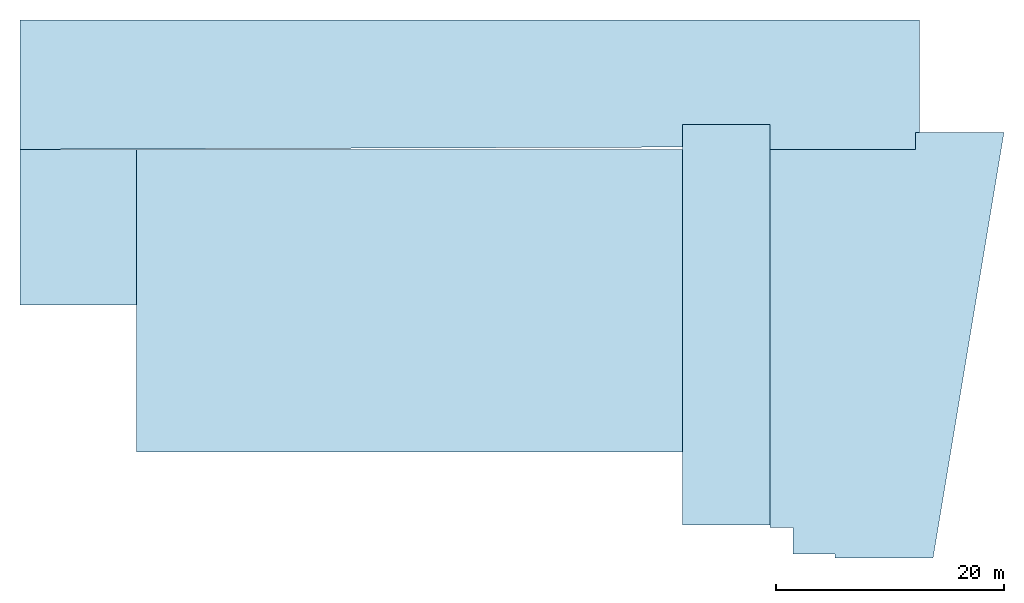
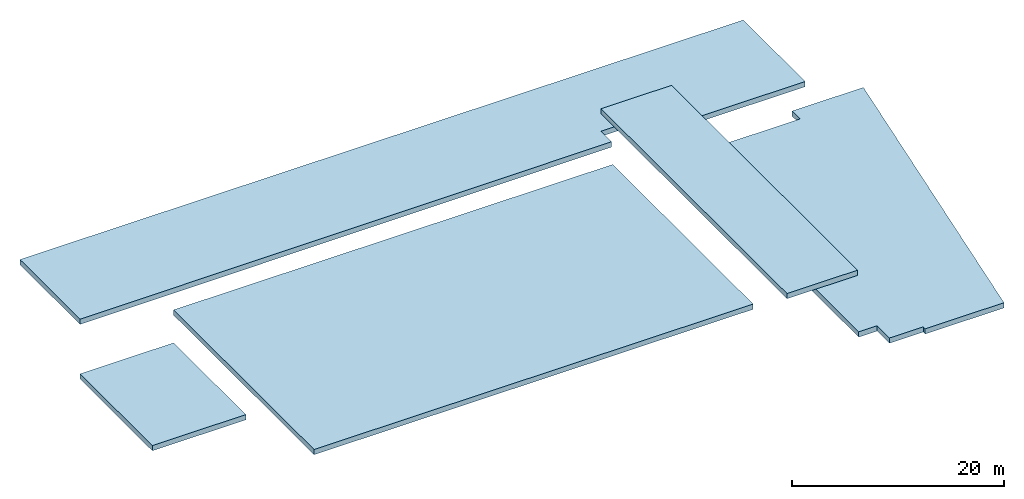
# One storey: 5 slabs.
"""IFC2X3 building model written with IfcOpenShell, lengths in metres."""

from ifc_helpers import new_model, entity, si_unit, converted_unit, derived_unit, frame, origin_with_axes, place, context, project, spatial, polyline, outline, extrude, type_object, element, save


model = new_model("IFC2X3")

# Units and contexts
context_of_model_1 = context(None, 3, world=origin_with_axes())
context_of_model_2 = context(None, 3, world=origin_with_axes())
context_of_model_3 = context(None, 2, world=origin_with_axes())
context_of_model_4 = context(None, 3, world=origin_with_axes())
ifc_project = project(units=[si_unit("LENGTHUNIT", "METRE"), si_unit("AREAUNIT", "SQUARE_METRE"), si_unit("ELECTRICCURRENTUNIT", "AMPERE"), si_unit("ELECTRICVOLTAGEUNIT", "VOLT"), si_unit("ELECTRICRESISTANCEUNIT", "OHM"), si_unit("POWERUNIT", "WATT"), si_unit("MASSUNIT", "GRAM"), si_unit("SOLIDANGLEUNIT", "STERADIAN"), si_unit("THERMODYNAMICTEMPERATUREUNIT", "KELVIN"), si_unit("PRESSUREUNIT", "PASCAL"), si_unit("LUMINOUSFLUXUNIT", "LUMEN"), si_unit("ILLUMINANCEUNIT", "LUX"), si_unit("FREQUENCYUNIT", "HERTZ"), si_unit("VOLUMEUNIT", "CUBIC_METRE"), si_unit("TIMEUNIT", "SECOND"), derived_unit("VOLUMETRICFLOWRATEUNIT", [(si_unit("TIMEUNIT", "SECOND"), -1), (si_unit("VOLUMEUNIT", "CUBIC_METRE"), 1)]), derived_unit("THERMALTRANSMITTANCEUNIT", [(si_unit("AREAUNIT", "SQUARE_METRE"), -1), (si_unit("THERMODYNAMICTEMPERATUREUNIT", "KELVIN"), -1), (si_unit("POWERUNIT", "WATT"), 1)]), converted_unit("PLANEANGLEUNIT", "DEGREE", entity("IfcPlaneAngleMeasure", 57.29577951308232), si_unit("PLANEANGLEUNIT", "RADIAN"), dimensions=[0, 0, 0, 0, 0, 0, 0])], contexts=[context_of_model_1, context_of_model_2, context_of_model_3, context_of_model_4])

# Site, building, storey
site = spatial("IfcSite", under=ifc_project, CompositionType="ELEMENT")
building_placement = place(None, origin_with_axes())
building = spatial("IfcBuilding", under=site, at=building_placement, Name="600", CompositionType="ELEMENT")
storey_placement = place(building_placement, frame((0.0, 0.0, 12.96000051498413), z_axis=(0.0, 0.0, 1.0), x_axis=(1.0, 0.0, 0.0)))
storey = spatial("IfcBuildingStorey", under=building, at=storey_placement, Name="3.etasje", CompositionType="ELEMENT", Elevation=12.96000051498413)

# Slabs
slab_type_1 = type_object("IfcSlabType", PredefinedType="ROOF")
slab_1_placement = place(storey_placement, frame((11.14999771118164, -40.32500076293945, -4.699999809265137), z_axis=(0.0, 0.0, 1.0), x_axis=(0.0, -1.0, 0.0)))
element("IfcSlab", 1, at=slab_1_placement, inside=storey, type_object=slab_type_1, PredefinedType="ROOF", context=context_of_model_1, shape_type="SweptSolid", body=[
    extrude(outline(polyline([(0.0, 0.0), (0.375, 0.0), (0.375, 8.591667175292969), (-36.97500133514404, 14.81666564941406), (-36.97500133514404, 7.050003051757813), (-35.47500133514404, 7.050003051757813), (-35.47500133514404, -5.699996948242188), (-2.325000762939453, -5.699996948242188), (-2.325000762939453, -3.699996948242188), (0.0, -3.699996948242188), (0.0, 0.0)])), origin_with_axes(), (0.0, 0.0, 1.0), 0.6),
])
slab_type_2 = type_object("IfcSlabType", PredefinedType="ROOF")
slab_2_placement = place(storey_placement, frame((-60.35000228881836, -18.5, -6.599999904632568), z_axis=(0.0, 0.0, 1.0), x_axis=(1.0, 0.0, 0.0)))
element("IfcSlab", 2, at=slab_2_placement, inside=storey, type_object=slab_type_2, PredefinedType="ROOF", context=context_of_model_1, shape_type="SweptSolid", body=[
    extrude(outline(polyline([(0.0, 0.0), (10.20000076293945, 0.0), (10.20000076293945, 13.65000057220459), (0.0, 13.65000057220459), (0.0, 0.0)])), origin_with_axes(), (0.0, 0.0, 1.0), 0.6),
])
slab_type_3 = type_object("IfcSlabType", PredefinedType="ROOF")
slab_3_placement = place(storey_placement, frame((-50.15000152587891, -31.40000152587891, -2.799999952316284), z_axis=(0.0, 0.0, 1.0), x_axis=(1.0, 0.0, 0.0)))
element("IfcSlab", 3, at=slab_3_placement, inside=storey, type_object=slab_type_3, PredefinedType="ROOF", context=context_of_model_1, shape_type="SweptSolid", body=[
    extrude(outline(polyline([(0.0, 0.0), (47.90000152587891, 0.0), (47.90000152587891, 26.5500020980835), (0.0, 26.5500020980835), (0.0, 0.0)])), origin_with_axes(), (0.0, 0.0, 1.0), 0.6),
])
slab_type_4 = type_object("IfcSlabType", PredefinedType="ROOF")
slab_4_placement = place(storey_placement, frame((5.450000762939453, -2.649999618530273, 2.299999952316284), z_axis=(0.0, 0.0, 1.0), x_axis=(-1.0, 0.0, 0.0)))
element("IfcSlab", 4, at=slab_4_placement, inside=storey, type_object=slab_type_4, PredefinedType="ROOF", context=context_of_model_1, shape_type="SweptSolid", body=[
    extrude(outline(polyline([(0.0, 0.0), (7.700000762939453, 0.0), (7.700000762939453, 35.15000343322754), (0.0, 35.15000343322754), (0.0, 0.0)])), origin_with_axes(), (0.0, 0.0, 1.0), 0.6),
])
slab_type_5 = type_object("IfcSlabType", PredefinedType="ROOF")
slab_5_placement = place(storey_placement, frame((-60.35000228881837, -4.849999427795411, -0.300000011920929), z_axis=(0.0, 0.0, 1.0), x_axis=(0.9999940752093595, 0.003442316978129094, 0.0)))
element("IfcSlab", 5, at=slab_5_placement, inside=storey, type_object=slab_type_5, PredefinedType="ROOF", context=context_of_model_1, shape_type="SweptSolid", body=[
    extrude(outline(polyline([(0.0, 0.0), (58.10034652120765, 0.0), (58.1072311551639, 1.999988150418719), (65.70718841555984, 1.9738265335061), (65.69841050660904, -0.5761585490114998), (78.89832924763286, -0.6215971226176862), (78.93860435562038, 11.07833336659809), (0.03907029573205278, 11.34993218142503), (0.0, 0.0)])), origin_with_axes(), (0.0, 0.0, 1.0), 0.6),
])

save(model, "model.ifc")
